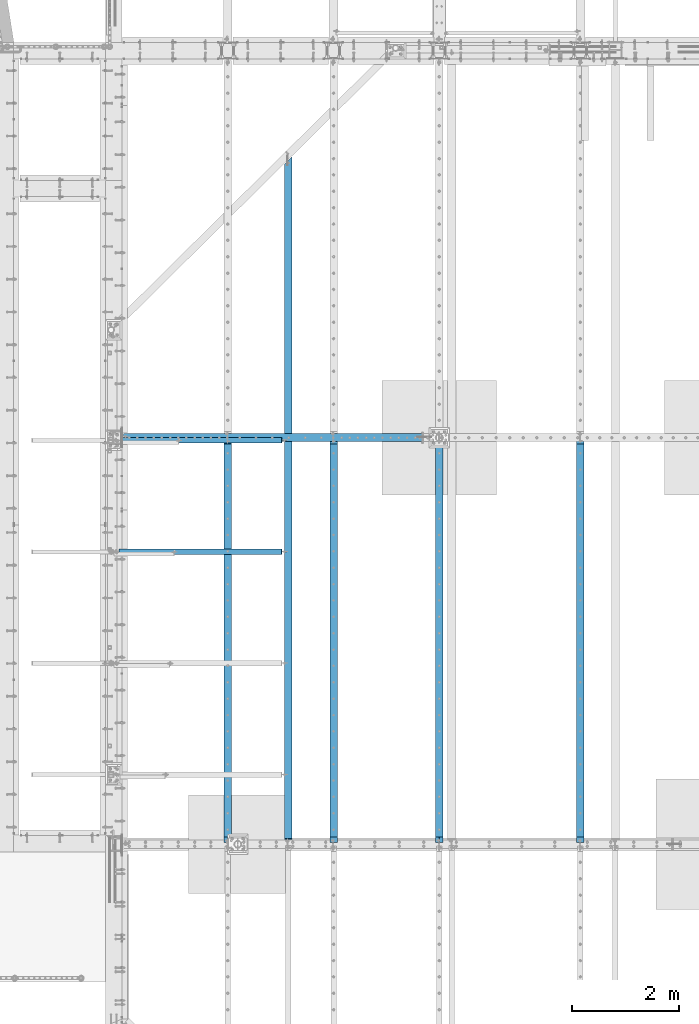
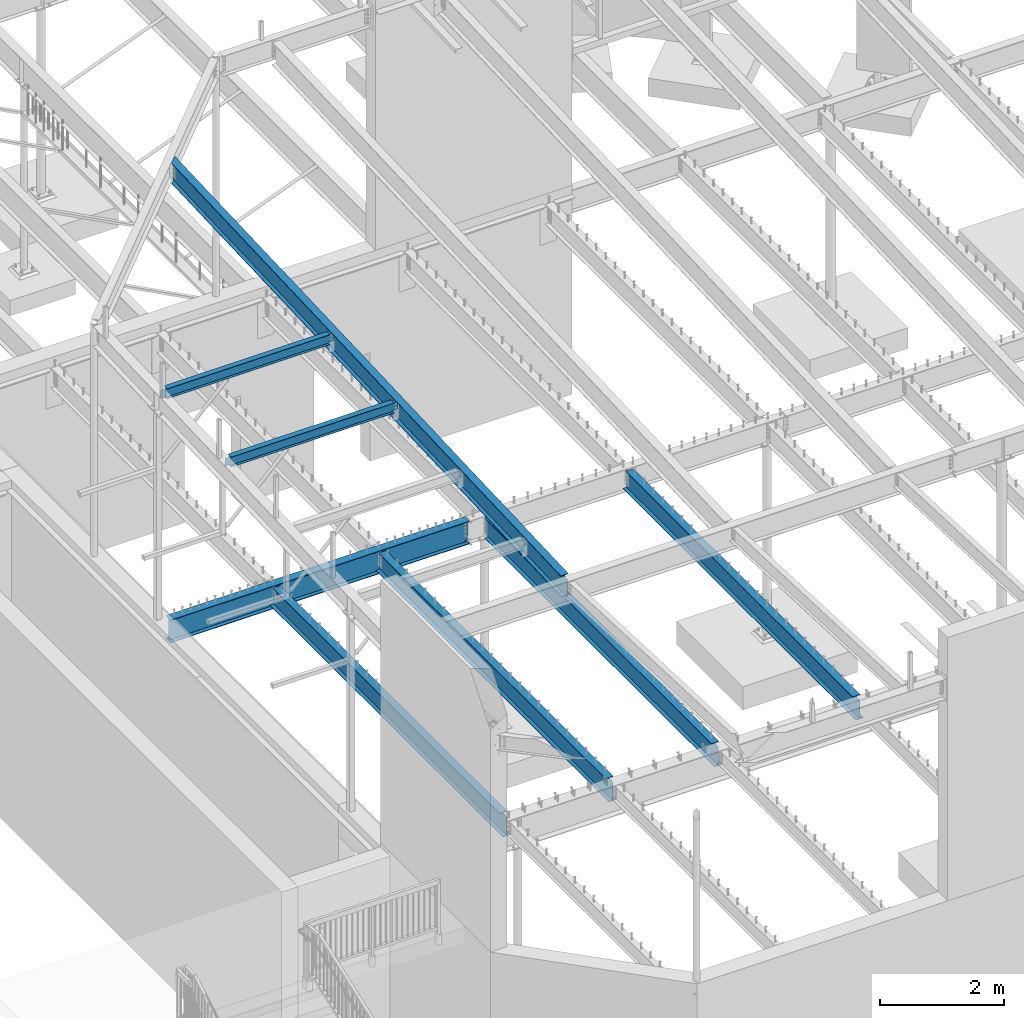
# One storey, part 312 of 975: 8 beams.
"""IFC2X3 building model written with IfcOpenShell, lengths in millimetres."""

from ifc_helpers import new_model, si_unit, frame, origin_with_axes, place, context, subcontext, project, spatial, faceted_brep, material, type_object, element, save


model = new_model("IFC2X3")

# Units and contexts
model_context = context("Model", 3, precision=1e-05, world=origin_with_axes())
body_context = subcontext(model_context, "Body", "Model", "MODEL_VIEW")
ifc_project = project(units=[si_unit("LENGTHUNIT", "METRE", prefix="MILLI"), si_unit("AREAUNIT", "SQUARE_METRE"), si_unit("VOLUMEUNIT", "CUBIC_METRE"), si_unit("MASSUNIT", "GRAM", prefix="KILO"), si_unit("TIMEUNIT", "SECOND"), si_unit("PLANEANGLEUNIT", "RADIAN"), si_unit("SOLIDANGLEUNIT", "STERADIAN"), si_unit("THERMODYNAMICTEMPERATUREUNIT", "DEGREE_CELSIUS"), si_unit("LUMINOUSINTENSITYUNIT", "LUMEN")], contexts=[model_context])

# Site, building, storey
site_placement = place(None, origin_with_axes())
site = spatial("IfcSite", under=ifc_project, at=site_placement, CompositionType="ELEMENT")
building_placement = place(site_placement, origin_with_axes())
building = spatial("IfcBuilding", under=site, at=building_placement, Name="Undefined", CompositionType="ELEMENT")
storey_placement = place(building_placement, origin_with_axes())
storey = spatial("IfcBuildingStorey", under=building, at=storey_placement, Name="Undefined", CompositionType="ELEMENT", Elevation=0.0)

# Beams
ifc_material = material(Name="STEEL/A992")
beam_type_1 = type_object("IfcBeamType", Name="W8X10", PredefinedType="NOTDEFINED")
beam_1_placement = place(storey_placement, frame((2143.30864129936, 11265.958333435, 8346.36184779769), z_axis=(0.00183540099936135, 0.0, -0.999998315650167), x_axis=(0.999998315650167, 0.0, 0.00183540099935813)))
element("IfcBeam", 1, at=beam_1_placement, inside=storey, type_object=beam_type_1, material=ifc_material, Name="BEAM", ObjectType="W8X10", context=body_context, shape_type="Brep", body=[
    faceted_brep([(3152.41325517504, -2.38125000000036, -95.2499999987976), (3152.41325517504, -50.7999999999993, -95.2499999987976), (3152.41325517504, -50.7999999999993, -100.012499998797), (3152.41325517504, 50.7999999999993, -100.012499998797), (3152.41325517504, 50.7999999999993, -95.2499999987976), (3152.41325517504, 2.38125000000036, -95.2499999987976), (3152.41325517503, 2.38125000000036, -87.3124997870182), (3152.41325517503, -2.38125000000036, -87.3124997870182), (3153.37998509762, 2.38125000000036, -82.4524202689681), (3153.37998509762, -2.38125000000036, -82.4524202689681), (3156.1329989981, 2.38125000000036, -78.332243800809), (3156.1329989981, -2.38125000000036, -78.332243800809), (3160.25317546626, 2.38125000000036, -75.5792299003297), (3160.25317546626, -2.38125000000036, -75.5792299003297), (3165.11325498431, 2.38125000000036, -74.6124999777348), (3165.11325498431, -2.38125000000036, -74.6124999777348), (3241.31325516489, -2.38125000000036, -74.6124999776475), (3241.31325516489, 2.38125000000036, -74.6124999776475), (3152.41325517298, 50.7999999999993, 95.2500000012406), (3152.41325517298, 2.38125000000036, 95.2500000012406), (118.268769591082, 2.38125000000036, 95.2499999999136), (118.268769591082, 50.8000000000002, 95.2499999999136), (118.268769590937, -2.38125000000036, -87.312499810695), (118.268769590937, 2.38125000000036, -87.312499810695), (118.268769590941, 2.38125000000036, -95.2500000000064), (118.268769590941, 50.8000000000002, -95.2500000000064), (118.268769590944, 50.8000000000002, -100.012500000005), (118.268769590943, -50.8000000000002, -100.012499810899), (118.268769590941, -50.8000000000002, -95.2500000000064), (118.268769590941, -2.38125000000036, -95.2500000000064), (117.302039668346, -2.38125000000036, -82.4524202926505), (117.302039668346, 2.38125000000036, -82.4524202926505), (114.549025767866, -2.38125000000036, -78.3322438245004), (114.549025767866, 2.38125000000036, -78.3322438245004), (110.42884929971, -2.38125000000036, -75.5792299240211), (110.42884929971, 2.38125000000036, -75.5792299240211), (105.568769781664, -2.38125000000036, -74.6125000014354), (105.568769781664, 2.38125000000036, -74.6125000014354), (29.3687774666446, -2.38125000000036, -74.6125000038883), (29.3687774666446, 2.38125000000036, -74.6125000038883), (29.3687774666446, -2.38125000000036, 74.6124999961967), (29.3687774666446, 2.38125000000036, 74.6124999961967), (105.568769781842, -2.38125000000036, 74.6124999982885), (105.568769781842, 2.38125000000036, 74.6124999982885), (110.428849299887, -2.38125000000036, 75.5792299208715), (110.428849299887, 2.38125000000036, 75.5792299208715), (114.54902576804, -2.38125000000036, 78.3322438213418), (114.54902576804, 2.38125000000036, 78.3322438213418), (117.302039668516, -2.38125000000036, 82.4524202894881), (117.302039668516, 2.38125000000036, 82.4524202894881), (118.268769591102, -2.38125000000036, 87.3124998075264), (118.268769591102, 2.38125000000036, 87.3124998075264), (3152.41325517298, -50.7999999999993, 100.012500001241), (3152.41325517298, 50.7999999999993, 100.012500001241), (118.268769591083, 50.8000000000002, 100.012499999913), (118.268769591084, -50.8000000000002, 100.012499999913), (3152.41325517298, -50.7999999999993, 95.2500000012406), (118.268769591082, -50.8000000000002, 95.2499999999136), (3152.41325517298, -2.38125000000036, 95.2500000012406), (118.268769591082, -2.38125000000036, 95.2499999999136), (3152.41325517297, -2.38125000000036, 87.3124998316434), (3152.41325517297, 2.38125000000036, 87.3124998316434), (3153.37998509556, -2.38125000000036, 82.4524203135952), (3153.37998509556, 2.38125000000036, 82.4524203135952), (3156.13299899604, -2.38125000000036, 78.3322438454416), (3156.13299899604, 2.38125000000036, 78.3322438454416), (3160.25317546419, -2.38125000000036, 75.5792299449658), (3160.25317546419, 2.38125000000036, 75.5792299449658), (3165.11325498224, -2.38125000000036, 74.6125000223801), (3165.11325498224, 2.38125000000036, 74.6125000223801), (3241.31325516495, -2.38125000000036, 74.612500022411), (3241.31325516495, 2.38125000000036, 74.612500022411)], [[[0, 1, 2, 3, 4, 5, 6, 7]], [[7, 6, 8, 9]], [[9, 8, 10, 11]], [[11, 10, 12, 13]], [[13, 12, 14, 15]], [[16, 15, 14, 17]], [[18, 19, 20, 21]], [[22, 23, 24, 25, 26, 27, 28, 29]], [[30, 31, 23, 22]], [[32, 33, 31, 30]], [[34, 35, 33, 32]], [[36, 37, 35, 34]], [[38, 39, 37, 36]], [[40, 41, 39, 38]], [[42, 43, 41, 40]], [[44, 45, 43, 42]], [[46, 47, 45, 44]], [[48, 49, 47, 46]], [[50, 51, 49, 48]], [[52, 53, 54, 55]], [[56, 52, 55, 57]], [[58, 56, 57, 59]], [[55, 54, 21, 20, 51, 50, 59, 57]], [[53, 18, 21, 54]], [[52, 56, 58, 60, 61, 19, 18, 53]], [[62, 63, 61, 60]], [[64, 65, 63, 62]], [[66, 67, 65, 64]], [[68, 69, 67, 66]], [[70, 71, 69, 68]], [[71, 70, 16, 17]], [[12, 10, 8, 6, 5, 24, 23, 31, 33, 35, 37, 39, 41, 43, 45, 47, 49, 51, 20, 19, 61, 63, 65, 67, 69, 71, 17, 14]], [[25, 24, 5, 4]], [[26, 25, 4, 3]], [[27, 26, 3, 2]], [[28, 27, 2, 1]], [[29, 28, 1, 0]], [[70, 68, 66, 64, 62, 60, 58, 59, 50, 48, 46, 44, 42, 40, 38, 36, 34, 32, 30, 22, 29, 0, 7, 9, 11, 13, 15, 16]]]),
])
beam_2_placement = place(storey_placement, frame((2143.37858342747, 13341.3500001017, 8428.96871764723), z_axis=(0.00253481800087729, 0.0, -0.999996787343691), x_axis=(0.999996787343691, 0.0, 0.00253481800087123)))
element("IfcBeam", 2, at=beam_2_placement, inside=storey, type_object=beam_type_1, material=ifc_material, Name="BEAM", ObjectType="W8X10", context=body_context, shape_type="Brep", body=[
    faceted_brep([(3152.27831587957, -2.38125000000036, -95.2499999993579), (3152.27831587957, -50.7999999999993, -95.2499999993579), (3152.27831587957, -50.7999999999993, -100.012499999364), (3152.27831587957, 50.7999999999993, -100.012499999364), (3152.27831587957, 50.7999999999993, -95.2499999993579), (3152.27831587957, 2.38125000000036, -95.2499999993579), (3152.27831587956, 2.38125000000036, -87.3124997950435), (3152.27831587956, -2.38125000000036, -87.3124997950435), (3153.24504580215, 2.38125000000036, -82.4524202769862), (3153.24504580215, -2.38125000000036, -82.4524202769862), (3155.99805970263, 2.38125000000036, -78.3322438088198), (3155.99805970263, -2.38125000000036, -78.3322438088198), (3160.11823617078, 2.38125000000036, -75.5792299083314), (3160.11823617078, -2.38125000000036, -75.5792299083314), (3164.97831568883, 2.38125000000036, -74.6124999857366), (3164.97831568883, -2.38125000000036, -74.6124999857366), (3241.17831587894, -2.38125000000036, -74.6124999856656), (3241.17831587894, 2.38125000000036, -74.6124999856656), (118.268844597442, 2.38125000000036, 95.2500000001073), (118.268844597442, 50.7999999999993, 95.2500000001073), (3152.27831587961, 50.7999999999993, 95.2500000008113), (3152.27831587961, 2.38125000000036, 95.2500000008113), (118.268844597389, -2.38125000000036, -87.3124998057883), (118.268844597389, 2.38125000000036, -87.3124998057883), (118.268844597391, 2.38125000000036, -95.2500000000582), (118.268844597391, 50.7999999999993, -95.2500000000582), (118.268844597392, 50.7999999999993, -100.012500000063), (118.268844597392, -50.7999999999993, -100.012500000063), (118.268844597391, -50.7999999999993, -95.2500000000582), (118.268844597391, -2.38125000000036, -95.2500000000582), (117.302114674805, -2.38125000000036, -82.452420287731), (117.302114674805, 2.38125000000036, -82.452420287731), (114.54910077433, -2.38125000000036, -78.3322438195682), (114.54910077433, 2.38125000000036, -78.3322438195682), (110.428924306178, -2.38125000000036, -75.5792299190871), (110.428924306178, 2.38125000000036, -75.5792299190871), (105.568844788134, -2.38125000000036, -74.6124999964995), (105.568844788134, 2.38125000000036, -74.6124999964995), (29.3688445977368, -2.38125000000036, -74.6124999965978), (29.3688445977368, 2.38125000000036, -74.6124999965978), (29.3688445978046, -2.38125000000036, 74.6125000039792), (29.3688445978046, 2.38125000000036, 74.6125000039792), (105.568844788149, -2.38125000000036, 74.612500003961), (105.568844788149, 2.38125000000036, 74.612500003961), (110.428924306195, -2.38125000000036, 75.5792299265577), (110.428924306195, 2.38125000000036, 75.5792299265577), (114.54910077435, -2.38125000000036, 78.3322438270443), (114.54910077435, 2.38125000000036, 78.3322438270443), (117.302114674831, -2.38125000000036, 82.4524202952089), (117.302114674831, 2.38125000000036, 82.4524202952089), (118.268844597422, -2.38125000000036, 87.3124998132698), (118.268844597422, 2.38125000000036, 87.3124998132698), (118.268844597442, -50.7999999999993, 100.012500000114), (118.268844597442, 50.7999999999993, 100.012500000114), (118.268844597442, -2.38125000000036, 95.2500000001073), (118.268844597442, -50.7999999999993, 95.2500000001073), (3152.27831587961, -2.38125000000036, 95.2500000008113), (3152.27831587961, -50.7999999999993, 95.2500000008113), (3152.27831587961, -50.7999999999993, 100.012500000814), (3152.27831587961, 50.7999999999993, 100.012500000814), (3152.2783158796, -2.38125000000036, 87.3124998240128), (3152.2783158796, 2.38125000000036, 87.3124998240128), (3153.24504580219, -2.38125000000036, 82.4524203059536), (3153.24504580219, 2.38125000000036, 82.4524203059536), (3155.99805970266, -2.38125000000036, 78.3322438377927), (3155.99805970266, 2.38125000000036, 78.3322438377927), (3160.11823617082, -2.38125000000036, 75.5792299373079), (3160.11823617082, 2.38125000000036, 75.5792299373079), (3164.97831568886, -2.38125000000036, 74.6125000147222), (3164.97831568886, 2.38125000000036, 74.6125000147222), (3241.17831587901, -2.38125000000036, 74.6125000147385), (3241.17831587901, 2.38125000000036, 74.6125000147385)], [[[0, 1, 2, 3, 4, 5, 6, 7]], [[7, 6, 8, 9]], [[9, 8, 10, 11]], [[11, 10, 12, 13]], [[13, 12, 14, 15]], [[16, 15, 14, 17]], [[18, 19, 20, 21]], [[22, 23, 24, 25, 26, 27, 28, 29]], [[30, 31, 23, 22]], [[32, 33, 31, 30]], [[34, 35, 33, 32]], [[36, 37, 35, 34]], [[38, 39, 37, 36]], [[40, 41, 39, 38]], [[42, 43, 41, 40]], [[44, 45, 43, 42]], [[46, 47, 45, 44]], [[48, 49, 47, 46]], [[50, 51, 49, 48]], [[52, 53, 19, 18, 51, 50, 54, 55]], [[55, 54, 56, 57]], [[52, 55, 57, 58]], [[53, 52, 58, 59]], [[19, 53, 59, 20]], [[58, 57, 56, 60, 61, 21, 20, 59]], [[62, 63, 61, 60]], [[64, 65, 63, 62]], [[66, 67, 65, 64]], [[68, 69, 67, 66]], [[70, 71, 69, 68]], [[71, 70, 16, 17]], [[12, 10, 8, 6, 5, 24, 23, 31, 33, 35, 37, 39, 41, 43, 45, 47, 49, 51, 18, 21, 61, 63, 65, 67, 69, 71, 17, 14]], [[25, 24, 5, 4]], [[26, 25, 4, 3]], [[27, 26, 3, 2]], [[28, 27, 2, 1]], [[29, 28, 1, 0]], [[70, 68, 66, 64, 62, 60, 56, 54, 50, 48, 46, 44, 42, 40, 38, 36, 34, 32, 30, 22, 29, 0, 7, 9, 11, 13, 15, 16]]]),
])
beam_type_2 = type_object("IfcBeamType", Name="W16X31", PredefinedType="NOTDEFINED")
beam_3_placement = place(storey_placement, frame((5413.375, 5828.01507865059, 8028.15596126621), z_axis=(0.0, -0.0408708719929791, 0.99916443682836), x_axis=(0.0, 0.99916443682836, 0.0408708719929791)))
element("IfcBeam", 3, at=beam_3_placement, inside=storey, type_object=beam_type_2, material=ifc_material, Name="BEAM", ObjectType="W16X31", context=body_context, shape_type="Brep", body=[
    faceted_brep([(11.0204511385882, -3.17500000000018, -169.86250000038), (11.0204511385882, 3.17500000000018, -169.86250000038), (60.5217159683571, 3.17500000000018, -169.862500000362), (60.5217159683571, -3.17500000000018, -169.862500000362), (65.3817954864035, 3.17500000000018, -170.829229922949), (65.3817954864035, -3.17500000000018, -170.829229922949), (69.5019719545571, 3.17500000000018, -173.582243823425), (69.5019719545571, -3.17500000000018, -173.582243823425), (72.2549858550365, 3.17500000000018, -177.702420291577), (72.2549858550365, -3.17500000000018, -177.702420291577), (73.2217157776258, -3.17500000000018, -182.562499809622), (73.2217157776258, 3.17500000000018, -182.562499809622), (73.2217157776304, 3.17500000000018, -190.499999999971), (73.2217157776304, 69.8500000000004, -190.499999999971), (73.2217157776322, 69.8500000000004, -201.61249999997), (73.2217157776322, -69.8500000000004, -201.61249999997), (73.2217157776304, -69.8500000000004, -190.499999999971), (73.2217157776304, -3.17500000000018, -190.499999999971), (12806.2725509733, -69.8500000000004, 190.500000004378), (12806.7271083497, -69.8500000000004, 201.612500004379), (111.321715777507, -69.8500000000004, 201.612500000033), (111.321715777512, -69.8500000000004, 190.500000000034), (12668.2506474183, 69.8500000000004, 201.612500004332), (111.321715777507, 69.8500000000004, 201.612500000033), (12667.7960900419, 69.8500000000004, 190.500000004333), (111.321715777512, 69.8500000000004, 190.500000000034), (12733.8871282137, 3.17500000000018, 190.500000004355), (111.321715777512, 3.17500000000018, 190.500000000034), (98.6217159682528, -3.17500000000018, 169.862500000014), (98.6217159682528, 3.17500000000018, 169.862500000014), (24.9169195036002, 3.17500000000018, 169.862499999993), (24.9169195036002, -3.17500000000018, 169.862499999993), (103.481795486297, -3.17500000000018, 170.829229922605), (103.481795486297, 3.17500000000018, 170.829229922605), (107.601971954449, -3.17500000000018, 173.582243823088), (107.601971954449, 3.17500000000018, 173.582243823088), (110.354985854926, -3.17500000000018, 177.702420291245), (110.354985854926, 3.17500000000018, 177.702420291245), (111.321715777513, -3.17500000000018, 182.562499809294), (111.321715777513, 3.17500000000018, 182.562499809294), (111.321715777512, -3.17500000000018, 190.500000000034), (12740.1815128015, -3.17500000000018, 190.500000004356), (12718.3023038791, 3.17500000000018, -190.499999995643), (12724.5966884669, -3.17500000000018, -190.49999999564), (12790.6877266387, -69.8500000000004, -190.499999995618), (12790.2331692623, -69.8500000000004, -201.612499995617), (12651.7567083309, 69.8500000000004, -201.612499995665), (12652.2112657073, 69.8500000000004, -190.499999995665)], [[[0, 1, 2, 3]], [[3, 2, 4, 5]], [[5, 4, 6, 7]], [[7, 6, 8, 9]], [[10, 11, 12, 13, 14, 15, 16, 17]], [[9, 8, 11, 10]], [[18, 19, 20, 21]], [[19, 22, 23, 20]], [[22, 24, 25, 23]], [[24, 26, 27, 25]], [[28, 29, 30, 31]], [[32, 33, 29, 28]], [[34, 35, 33, 32]], [[36, 37, 35, 34]], [[38, 39, 37, 36]], [[20, 23, 25, 27, 39, 38, 40, 21]], [[41, 18, 21, 40]], [[42, 26, 24, 22, 19, 18, 41, 43, 44, 45, 46, 47]], [[44, 43, 17, 16]], [[45, 44, 16, 15]], [[46, 45, 15, 14]], [[47, 46, 14, 13]], [[42, 47, 13, 12]], [[6, 4, 2, 1, 30, 29, 33, 35, 37, 39, 27, 26, 42, 12, 11, 8]], [[31, 30, 1, 0]], [[43, 41, 40, 38, 36, 34, 32, 28, 31, 0, 3, 5, 7, 9, 10, 17]]]),
])
beam_type_3 = type_object("IfcBeamType", Name="W16X26", PredefinedType="NOTDEFINED")
beam_4_placement = place(storey_placement, frame((10858.5, 5819.775, 3736.975), z_axis=(0.0, 0.0, 1.0), x_axis=(0.0, 1.0, 0.0)))
element("IfcBeam", 4, at=beam_4_placement, inside=storey, type_object=beam_type_3, material=ifc_material, Name="BEAM", ObjectType="W16X26", context=body_context, shape_type="Brep", body=[
    faceted_brep([(119.856250190734, -3.17499999999927, 174.625), (119.856250190734, 3.17499999999927, 174.625), (30.9562499999956, 3.17499999999927, 174.625), (30.9562499999956, -3.17499999999927, 174.625), (124.716329708779, -3.17499999999927, 175.591729922588), (124.716329708779, 3.17499999999927, 175.591729922588), (128.836506176933, -3.17499999999927, 178.344743823066), (128.836506176933, 3.17499999999927, 178.344743823066), (131.589520077411, -3.17499999999927, 182.46492029122), (131.589520077411, 3.17499999999927, 182.46492029122), (132.556249999999, -3.17499999999927, 187.324999809266), (132.556249999999, 3.17499999999927, 187.324999809266), (132.556249999999, -69.8500000000004, 200.025), (132.556249999999, 69.8500000000004, 200.025), (132.556249999999, 69.8500000000004, 190.5), (132.556249999999, 3.17499999999927, 190.5), (132.556249999999, -3.17499999999927, 190.5), (132.556249999999, -69.8500000000004, 190.5), (30.9562499999956, -3.17499999999927, -190.5), (30.9562499999956, -69.8499999999985, -190.5), (7543.00625, -69.8499999999985, -190.5), (7543.00625, -3.17499999999927, -190.5), (30.9562499999956, -69.8499999999985, -200.025), (7543.00625, -69.8499999999985, -200.025), (30.9562499999956, 69.8499999999985, -200.025), (7543.00625, 69.8499999999985, -200.025), (30.9562499999956, 69.8499999999985, -190.5), (7543.00625, 69.8499999999985, -190.5), (30.9562499999956, 3.17499999999927, -190.5), (7543.00625, 3.17499999999927, -190.5), (7543.00625, 3.17499999999927, 174.625), (7543.00625, -3.17499999999927, 174.625), (7466.80624980926, 3.17499999999927, 174.625), (7466.80624980926, -3.17499999999927, 174.625), (7461.94617029122, 3.17499999999927, 175.591729922588), (7461.94617029122, -3.17499999999927, 175.591729922588), (7457.82599382307, 3.17499999999927, 178.344743823066), (7457.82599382307, -3.17499999999927, 178.344743823066), (7455.07297992259, 3.17499999999927, 182.46492029122), (7455.07297992259, -3.17499999999927, 182.46492029122), (7454.10625, 3.17499999999927, 187.324999809266), (7454.10625, -3.17499999999927, 187.324999809266), (7454.10625, -69.8499999999985, 200.025), (7454.10625, -69.8499999999985, 190.5), (7454.10625, -3.17499999999927, 190.5), (7454.10625, 3.17499999999927, 190.5), (7454.10625, 69.8499999999985, 190.5), (7454.10625, 69.8499999999985, 200.025)], [[[0, 1, 2, 3]], [[4, 5, 1, 0]], [[6, 7, 5, 4]], [[8, 9, 7, 6]], [[10, 11, 9, 8]], [[12, 13, 14, 15, 11, 10, 16, 17]], [[18, 19, 20, 21]], [[19, 22, 23, 20]], [[22, 24, 25, 23]], [[24, 26, 27, 25]], [[26, 28, 29, 27]], [[21, 20, 23, 25, 27, 29, 30, 31]], [[31, 30, 32, 33]], [[33, 32, 34, 35]], [[35, 34, 36, 37]], [[37, 36, 38, 39]], [[39, 38, 40, 41]], [[42, 43, 44, 41, 40, 45, 46, 47]], [[43, 42, 12, 17]], [[44, 43, 17, 16]], [[8, 6, 4, 0, 3, 18, 21, 31, 33, 35, 37, 39, 41, 44, 16, 10]], [[28, 26, 24, 22, 19, 18, 3, 2]], [[45, 40, 38, 36, 34, 32, 30, 29, 28, 2, 1, 5, 7, 9, 11, 15]], [[46, 45, 15, 14]], [[47, 46, 14, 13]], [[42, 47, 13, 12]]]),
])
beam_5_placement = place(storey_placement, frame((8229.6, 5819.775, 3736.975), z_axis=(0.0, 0.0, 1.0), x_axis=(0.0, 1.0, 0.0)))
element("IfcBeam", 5, at=beam_5_placement, inside=storey, type_object=beam_type_3, material=ifc_material, Name="BEAM", ObjectType="W16X26", context=body_context, shape_type="Brep", body=[
    faceted_brep([(119.856250190734, -3.17499999999927, 174.625), (119.856250190734, 3.17499999999927, 174.625), (30.9562499999956, 3.17499999999927, 174.625), (30.9562499999956, -3.17499999999927, 174.625), (124.716329708779, -3.17499999999927, 175.591729922588), (124.716329708779, 3.17499999999927, 175.591729922588), (128.836506176933, -3.17499999999927, 178.344743823066), (128.836506176933, 3.17499999999927, 178.344743823066), (131.589520077411, -3.17499999999927, 182.46492029122), (131.589520077411, 3.17499999999927, 182.46492029122), (132.556249999999, -3.17499999999927, 187.324999809266), (132.556249999999, 3.17499999999927, 187.324999809266), (132.556249999999, -69.8500000000004, 200.025), (132.556249999999, 69.8500000000004, 200.025), (132.556249999999, 69.8500000000004, 190.5), (132.556249999999, 3.17499999999927, 190.5), (132.556249999999, -3.17499999999927, 190.5), (132.556249999999, -69.8500000000004, 190.5), (30.9562499999956, -3.17499999999927, -190.5), (30.9562499999956, -69.8499999999985, -190.5), (7543.00625, -69.8499999999985, -190.5), (7543.00625, -3.17499999999927, -190.5), (30.9562499999956, -69.8499999999985, -200.025), (7543.00625, -69.8499999999985, -200.025), (30.9562499999956, 69.8499999999985, -200.025), (7447.75625, 69.8500000000004, -200.025), (7447.75625, 3.47549991607775, -200.025), (7543.00625, 3.47549991607775, -200.025), (30.9562499999956, 69.8499999999985, -190.5), (7447.75625, 69.8500000000004, -190.5), (7447.75625, 3.47549991607775, -190.5), (7543.00625, 3.47549991607775, -190.5), (30.9562499999956, 3.17499999999927, -190.5), (7543.00625, 3.17499999999927, -190.5), (7543.00625, 3.17499999999927, 174.625), (7543.00625, -3.17499999999927, 174.625), (7466.80624980926, 3.17499999999927, 174.625), (7466.80624980926, -3.17499999999927, 174.625), (7461.94617029122, 3.17499999999927, 175.591729922588), (7461.94617029122, -3.17499999999927, 175.591729922588), (7457.82599382307, 3.17499999999927, 178.344743823066), (7457.82599382307, -3.17499999999927, 178.344743823066), (7455.07297992259, 3.17499999999927, 182.46492029122), (7455.07297992259, -3.17499999999927, 182.46492029122), (7454.10625, 3.17499999999927, 187.324999809266), (7454.10625, -3.17499999999927, 187.324999809266), (7454.10625, -69.8499999999985, 200.025), (7454.10625, -69.8499999999985, 190.5), (7454.10625, -3.17499999999927, 190.5), (7454.10625, 3.17499999999927, 190.5), (7454.10625, 69.8499999999985, 190.5), (7454.10625, 69.8499999999985, 200.025)], [[[0, 1, 2, 3]], [[4, 5, 1, 0]], [[6, 7, 5, 4]], [[8, 9, 7, 6]], [[10, 11, 9, 8]], [[12, 13, 14, 15, 11, 10, 16, 17]], [[18, 19, 20, 21]], [[19, 22, 23, 20]], [[23, 22, 24, 25, 26, 27]], [[24, 28, 29, 25]], [[30, 26, 25, 29]], [[31, 27, 26, 30]], [[29, 28, 32, 33, 31, 30]], [[21, 20, 23, 27, 31, 33, 34, 35]], [[35, 34, 36, 37]], [[37, 36, 38, 39]], [[39, 38, 40, 41]], [[41, 40, 42, 43]], [[43, 42, 44, 45]], [[46, 47, 48, 45, 44, 49, 50, 51]], [[47, 46, 12, 17]], [[48, 47, 17, 16]], [[8, 6, 4, 0, 3, 18, 21, 35, 37, 39, 41, 43, 45, 48, 16, 10]], [[32, 28, 24, 22, 19, 18, 3, 2]], [[49, 44, 42, 40, 38, 36, 34, 33, 32, 2, 1, 5, 7, 9, 11, 15]], [[50, 49, 15, 14]], [[51, 50, 14, 13]], [[46, 51, 13, 12]]]),
])
beam_6_placement = place(storey_placement, frame((6260.04172920507, 5819.775, 3736.975), z_axis=(0.0, 0.0, 1.0), x_axis=(0.0, 1.0, 0.0)))
element("IfcBeam", 6, at=beam_6_placement, inside=storey, type_object=beam_type_3, material=ifc_material, Name="BEAM", ObjectType="W16X26", context=body_context, shape_type="Brep", body=[
    faceted_brep([(119.856250190734, -3.17499999999927, 174.625), (119.856250190734, 3.17499999999927, 174.625), (30.9562499999956, 3.17499999999927, 174.625), (30.9562499999956, -3.17499999999927, 174.625), (124.716329708779, -3.17499999999927, 175.591729922588), (124.716329708779, 3.17499999999927, 175.591729922588), (128.836506176933, -3.17499999999927, 178.344743823066), (128.836506176933, 3.17499999999927, 178.344743823066), (131.589520077411, -3.17499999999927, 182.46492029122), (131.589520077411, 3.17499999999927, 182.46492029122), (132.556249999999, -3.17499999999927, 187.324999809266), (132.556249999999, 3.17499999999927, 187.324999809266), (132.556249999999, -69.8500000000004, 200.025), (132.556249999999, 69.8500000000004, 200.025), (132.556249999999, 69.8500000000004, 190.5), (132.556249999999, 3.17499999999927, 190.5), (132.556249999999, -3.17499999999927, 190.5), (132.556249999999, -69.8500000000004, 190.5), (30.9562499999956, -3.17499999999927, -190.5), (30.9562499999956, -69.8499999999985, -190.5), (7543.00625, -69.8499999999985, -190.5), (7543.00625, -3.17499999999927, -190.5), (30.9562499999956, -69.8499999999985, -200.025), (7543.00625, -69.8499999999985, -200.025), (30.9562499999956, 69.8499999999985, -200.025), (7543.00625, 69.8499999999985, -200.025), (30.9562499999956, 69.8499999999985, -190.5), (7543.00625, 69.8499999999985, -190.5), (30.9562499999956, 3.17499999999927, -190.5), (7543.00625, 3.17499999999927, -190.5), (7543.00625, 3.17499999999927, 174.625), (7543.00625, -3.17499999999927, 174.625), (7466.80624980926, 3.17499999999927, 174.625), (7466.80624980926, -3.17499999999927, 174.625), (7461.94617029122, 3.17499999999927, 175.591729922588), (7461.94617029122, -3.17499999999927, 175.591729922588), (7457.82599382307, 3.17499999999927, 178.344743823066), (7457.82599382307, -3.17499999999927, 178.344743823066), (7455.07297992259, 3.17499999999927, 182.46492029122), (7455.07297992259, -3.17499999999927, 182.46492029122), (7454.10625, 3.17499999999927, 187.324999809266), (7454.10625, -3.17499999999927, 187.324999809266), (7454.10625, -69.8499999999985, 200.025), (7454.10625, -69.8499999999985, 190.5), (7454.10625, -3.17499999999927, 190.5), (7454.10625, 3.17499999999927, 190.5), (7454.10625, 69.8499999999985, 190.5), (7454.10625, 69.8499999999985, 200.025)], [[[0, 1, 2, 3]], [[4, 5, 1, 0]], [[6, 7, 5, 4]], [[8, 9, 7, 6]], [[10, 11, 9, 8]], [[12, 13, 14, 15, 11, 10, 16, 17]], [[18, 19, 20, 21]], [[19, 22, 23, 20]], [[22, 24, 25, 23]], [[24, 26, 27, 25]], [[26, 28, 29, 27]], [[21, 20, 23, 25, 27, 29, 30, 31]], [[31, 30, 32, 33]], [[33, 32, 34, 35]], [[35, 34, 36, 37]], [[37, 36, 38, 39]], [[39, 38, 40, 41]], [[42, 43, 44, 41, 40, 45, 46, 47]], [[43, 42, 12, 17]], [[44, 43, 17, 16]], [[8, 6, 4, 0, 3, 18, 21, 31, 33, 35, 37, 39, 41, 44, 16, 10]], [[28, 26, 24, 22, 19, 18, 3, 2]], [[45, 40, 38, 36, 34, 32, 30, 29, 28, 2, 1, 5, 7, 9, 11, 15]], [[46, 45, 15, 14]], [[47, 46, 14, 13]], [[42, 47, 13, 12]]]),
])
beam_7_placement = place(storey_placement, frame((4290.48345841015, 5819.775, 3736.975), z_axis=(0.0, 0.0, 1.0), x_axis=(0.0, 1.0, 0.0)))
element("IfcBeam", 7, at=beam_7_placement, inside=storey, type_object=beam_type_3, material=ifc_material, Name="BEAM", ObjectType="W16X26", context=body_context, shape_type="Brep", body=[
    faceted_brep([(126.206250190731, -3.17499999999927, 174.625), (126.206250190731, 3.17499999999927, 174.625), (30.9562499999956, 3.17499999999927, 174.625), (30.9562499999956, -3.17499999999927, 174.625), (131.066329708777, -3.17499999999927, 175.591729922588), (131.066329708777, 3.17499999999927, 175.591729922588), (135.18650617693, -3.17499999999927, 178.344743823066), (135.18650617693, 3.17499999999927, 178.344743823066), (137.939520077409, -3.17499999999927, 182.46492029122), (137.939520077409, 3.17499999999927, 182.46492029122), (138.906249999996, -3.17499999999927, 187.324999809266), (138.906249999996, 3.17499999999927, 187.324999809266), (138.906249999996, -69.8499999999985, 200.025), (138.906249999996, 69.8499999999985, 200.025), (138.906249999996, 69.8499999999985, 190.5), (138.906249999996, 3.17499999999927, 190.5), (138.906249999996, -3.17499999999927, 190.5), (138.906249999996, -69.8499999999985, 190.5), (30.9562499999956, -3.17499999999927, -190.5), (30.9562499999956, -69.8499999999985, -190.5), (7543.00625, -69.8499999999985, -190.5), (7543.00625, -3.17499999999927, -190.5), (30.9562499999956, -69.8499999999985, -200.025), (7543.00625, -69.8499999999985, -200.025), (30.9562499999956, 69.8499999999985, -200.025), (7543.00625, 69.8499999999985, -200.025), (30.9562499999956, 69.8499999999985, -190.5), (7543.00625, 69.8499999999985, -190.5), (30.9562499999956, 3.17499999999927, -190.5), (7543.00625, 3.17499999999927, -190.5), (7543.00625, 3.17499999999927, 174.625), (7543.00625, -3.17499999999927, 174.625), (7466.80624980926, 3.17499999999927, 174.625), (7466.80624980926, -3.17499999999927, 174.625), (7461.94617029122, 3.17499999999927, 175.591729922588), (7461.94617029122, -3.17499999999927, 175.591729922588), (7457.82599382307, 3.17499999999927, 178.344743823066), (7457.82599382307, -3.17499999999927, 178.344743823066), (7455.07297992259, 3.17499999999927, 182.46492029122), (7455.07297992259, -3.17499999999927, 182.46492029122), (7454.10625, 3.17499999999927, 187.324999809266), (7454.10625, -3.17499999999927, 187.324999809266), (7454.10625, -69.8499999999985, 200.025), (7454.10625, -69.8499999999985, 190.5), (7454.10625, -3.17499999999927, 190.5), (7454.10625, 3.17499999999927, 190.5), (7454.10625, 69.8499999999985, 190.5), (7454.10625, 69.8499999999985, 200.025)], [[[0, 1, 2, 3]], [[4, 5, 1, 0]], [[6, 7, 5, 4]], [[8, 9, 7, 6]], [[10, 11, 9, 8]], [[12, 13, 14, 15, 11, 10, 16, 17]], [[18, 19, 20, 21]], [[19, 22, 23, 20]], [[22, 24, 25, 23]], [[24, 26, 27, 25]], [[26, 28, 29, 27]], [[21, 20, 23, 25, 27, 29, 30, 31]], [[31, 30, 32, 33]], [[33, 32, 34, 35]], [[35, 34, 36, 37]], [[37, 36, 38, 39]], [[39, 38, 40, 41]], [[42, 43, 44, 41, 40, 45, 46, 47]], [[43, 42, 12, 17]], [[44, 43, 17, 16]], [[8, 6, 4, 0, 3, 18, 21, 31, 33, 35, 37, 39, 41, 44, 16, 10]], [[28, 26, 24, 22, 19, 18, 3, 2]], [[45, 40, 38, 36, 34, 32, 30, 29, 28, 2, 1, 5, 7, 9, 11, 15]], [[46, 45, 15, 14]], [[47, 46, 14, 13]], [[42, 47, 13, 12]]]),
])
beam_type_4 = type_object("IfcBeamType", Name="W18X35", PredefinedType="NOTDEFINED")
beam_8_placement = place(storey_placement, frame((2320.925, 13392.15, 3711.575), z_axis=(0.0, 0.0, 1.0), x_axis=(1.0, 0.0, 0.0)))
element("IfcBeam", 8, at=beam_8_placement, inside=storey, type_object=beam_type_4, material=ifc_material, Name="BEAM", ObjectType="W18X35", context=body_context, shape_type="Brep", body=[
    faceted_brep([(5594.74701617765, -3.96875, 213.91549949646), (5594.74701617765, 3.96875, 213.91549949646), (5594.35003129485, 3.96875, 214.3125), (5594.35003129485, 76.2000000000007, 214.3125), (5583.23796853732, 76.2000000000007, 225.425), (5583.23796853732, -76.2000000000007, 225.425), (5594.35003129485, -76.2000000000007, 214.3125), (5594.35003129485, -3.96875, 214.3125), (25.3999999999992, -76.1999999999998, -225.425), (25.3999999999992, -76.1999999999998, -214.3125), (25.3999999999992, -3.96875, -214.3125), (25.3999999999992, -3.96875, 214.312499999999), (25.3999999999992, -76.1999999999998, 214.312499999999), (25.3999999999992, -76.1999999999998, 225.425), (25.3999999999992, 76.1999999999998, 225.425), (25.3999999999992, 76.1999999999998, 214.312499999999), (25.3999999999992, 3.96875, 214.312499999999), (25.3999999999992, 3.96875, -214.3125), (25.3999999999992, 76.1999999999998, -214.3125), (25.3999999999992, 76.1999999999998, -225.425), (5583.2379690027, 3.96875, -214.3125), (5583.2379690027, 76.2000000000007, -214.3125), (5594.35003176022, 76.2000000000007, -225.425), (5594.35003176022, -76.2000000000007, -225.425), (5583.2379690027, -76.2000000000007, -214.3125), (5583.2379690027, -3.96875, -214.3125), (5582.8409841199, 3.96875, -213.91549949646), (5582.8409841199, -3.96875, -213.91549949646), (5563.3940005188, 3.96875, -213.91549949646), (5563.3940005188, -3.96875, -213.91549949646), (5544.90673297694, 3.96875, -203.575605287907), (5544.90673297694, -3.96875, -203.575605287907), (5540.79404781973, 3.96875, -198.997422721185), (5540.79404781973, -3.96875, -198.997422721185), (5540.33918949547, 3.96875, -192.860074863893), (5540.33918949547, -3.96875, -192.860074863893), (5543.73204124722, 3.96875, -187.72563314086), (5543.73204124722, -3.96875, -187.72563314086), (5549.55623745191, 3.96875, -185.7375), (5549.55623745191, -3.96875, -185.7375), (5591.175, 3.96875, -185.7375), (5591.175, -3.96875, -185.7375), (5591.175, -3.96875, 185.7375), (5591.175, 3.96875, 185.7375), (5561.46223617017, 3.96875, 185.7375), (5561.46223617017, -3.96875, 185.7375), (5555.63803996548, 3.96875, 187.72563314086), (5555.63803996548, -3.96875, 187.72563314086), (5552.24518821373, 3.96875, 192.860074863893), (5552.24518821373, -3.96875, 192.860074863893), (5552.70004653799, 3.96875, 198.997422721185), (5552.70004653799, -3.96875, 198.997422721185), (5556.8127316952, 3.96875, 203.575605287907), (5556.8127316952, -3.96875, 203.575605287907), (5575.29999923706, 3.96875, 213.91549949646), (5575.29999923706, -3.96875, 213.91549949646)], [[[0, 1, 2, 3, 4, 5, 6, 7]], [[8, 9, 10, 11, 12, 13, 14, 15, 16, 17, 18, 19]], [[18, 17, 20, 21]], [[19, 18, 21, 22]], [[8, 19, 22, 23]], [[9, 8, 23, 24]], [[10, 9, 24, 25]], [[23, 22, 21, 20, 26, 27, 25, 24]], [[28, 29, 27, 26]], [[29, 28, 30, 31]], [[31, 30, 32, 33]], [[33, 32, 34, 35]], [[35, 34, 36, 37]], [[37, 36, 38, 39]], [[39, 38, 40, 41]], [[42, 41, 40, 43]], [[44, 45, 42, 43]], [[45, 44, 46, 47]], [[47, 46, 48, 49]], [[49, 48, 50, 51]], [[51, 50, 52, 53]], [[53, 52, 54, 55]], [[11, 10, 25, 27, 29, 31, 33, 35, 37, 39, 41, 42, 45, 47, 49, 51, 53, 55, 0, 7]], [[12, 11, 7, 6]], [[13, 12, 6, 5]], [[14, 13, 5, 4]], [[15, 14, 4, 3]], [[16, 15, 3, 2]], [[54, 52, 50, 48, 46, 44, 43, 40, 38, 36, 34, 32, 30, 28, 26, 20, 17, 16, 2, 1]], [[55, 54, 1, 0]]]),
])

save(model, "model.ifc")
